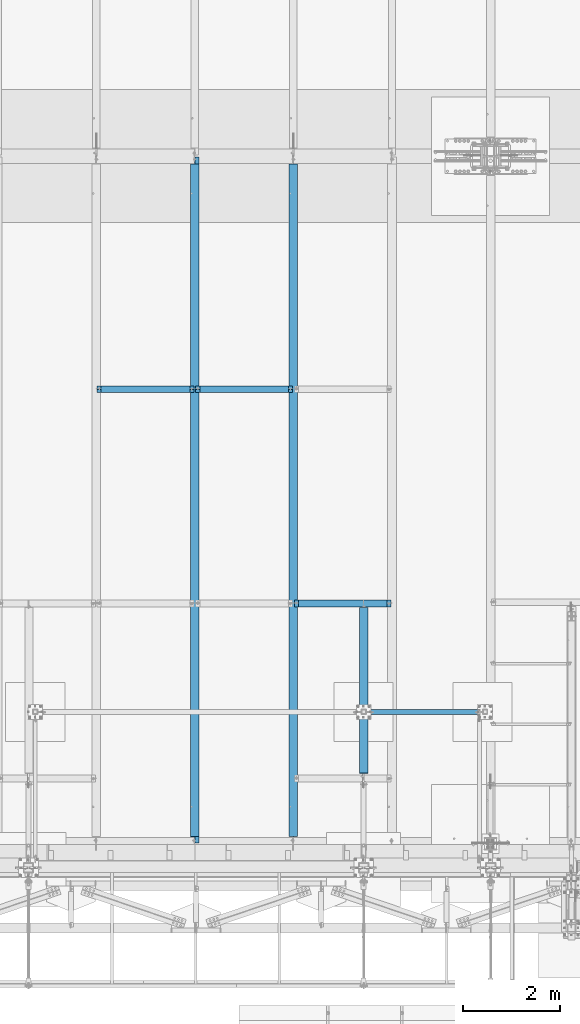
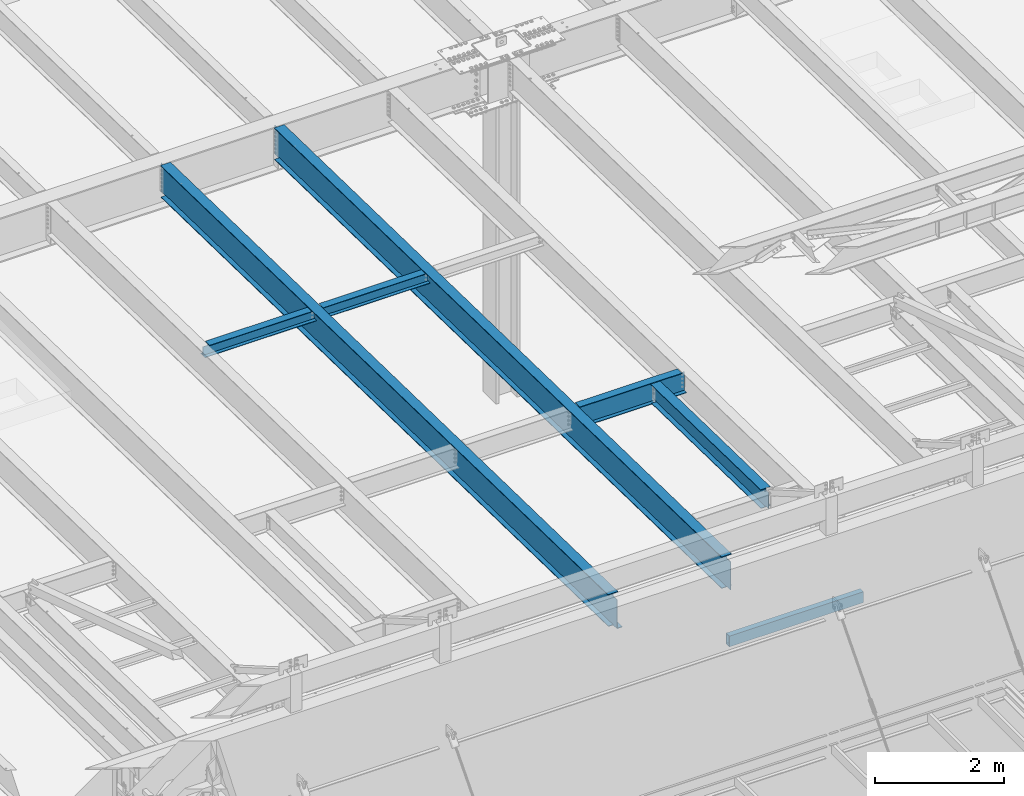
# One storey, part 1060 of 1763: 7 beams, 7 elements without a shape of their own.
"""IFC2X3 building model written with IfcOpenShell, lengths in millimetres."""

from ifc_helpers import new_model, si_unit, frame, origin_with_axes, place, context, subcontext, project, spatial, faceted_brep, material, type_object, element, aggregate, save


model = new_model("IFC2X3")

# Units and contexts
model_context = context("Model", 3, precision=1e-05, world=origin_with_axes())
body_context = subcontext(model_context, "Body", "Model", "MODEL_VIEW")
ifc_project = project(units=[si_unit("LENGTHUNIT", "METRE", prefix="MILLI"), si_unit("AREAUNIT", "SQUARE_METRE"), si_unit("VOLUMEUNIT", "CUBIC_METRE"), si_unit("MASSUNIT", "GRAM", prefix="KILO"), si_unit("TIMEUNIT", "SECOND"), si_unit("PLANEANGLEUNIT", "RADIAN"), si_unit("SOLIDANGLEUNIT", "STERADIAN"), si_unit("THERMODYNAMICTEMPERATUREUNIT", "DEGREE_CELSIUS"), si_unit("LUMINOUSINTENSITYUNIT", "LUMEN")], contexts=[model_context])

# Site, building, storey
site_placement = place(None, origin_with_axes())
site = spatial("IfcSite", under=ifc_project, at=site_placement, CompositionType="ELEMENT")
building_placement = place(site_placement, origin_with_axes())
building = spatial("IfcBuilding", under=site, at=building_placement, Name="Undefined", CompositionType="ELEMENT")
storey_placement = place(building_placement, origin_with_axes())
storey = spatial("IfcBuildingStorey", under=building, at=storey_placement, Name="Undefined", CompositionType="ELEMENT", Elevation=0.0)

# Assembly, beam
assembly_1_placement = place(storey_placement, origin_with_axes())
assembly_1 = element("IfcElementAssembly", 1, at=assembly_1_placement, inside=storey, Name="BEAM", AssemblyPlace="NOTDEFINED", PredefinedType="RIGID_FRAME")
ifc_material_1 = material(Name="STEEL/A992")
beam_type_1 = type_object("IfcBeamType", Name="W8X18", PredefinedType="NOTDEFINED")
beam_1_placement = place(assembly_1_placement, frame((-57530.4372736983, -4344.55643304548, 11905.5938232069), z_axis=(0.0, 0.0, 1.0), x_axis=(1.0, 0.0, 0.0)))
beam_1 = element("IfcBeam", 2, at=beam_1_placement, type_object=beam_type_1, material=ifc_material_1, Name="BEAM", ObjectType="W8X18", context=body_context, shape_type="Brep", body=[
    faceted_brep([(87.3125001907247, -3.17500000000018, 64.8275016680727), (87.3125001907247, 3.17500000000018, 64.8275016680727), (17.4624999999905, 3.17500000000018, 64.8275016680727), (17.4624999999905, -3.17500000000018, 64.8275016680727), (92.1725797087711, -3.17500000000018, 65.7942315906603), (92.1725797087711, 3.17500000000018, 65.7942315906603), (96.2927561769247, -3.17500000000018, 68.5472454911378), (96.2927561769247, 3.17500000000018, 68.5472454911378), (97.1527139098253, -3.17500000000018, 69.8342631898486), (97.1527139098253, 3.17500000000018, 69.8342631898486), (17.4624999999905, -3.17500000000018, -95.25), (17.4624999999905, -66.6750000000002, -95.25), (2014.53750000001, -66.6750000000002, -95.25), (2014.53750000001, -3.17500000000018, -95.25), (17.4624999999905, -66.6750000000002, -103.1875), (2014.53750000001, -66.6750000000002, -103.1875), (17.4624999999905, 66.6750000000002, -103.1875), (2014.53750000001, 66.6750000000002, -103.1875), (17.4624999999905, 66.6750000000002, -95.25), (2014.53750000001, 66.6750000000002, -95.25), (17.4624999999905, 3.17500000000018, -95.25), (2014.53750000001, 3.17500000000018, -95.25), (2014.53750000001, 3.17500000000018, 64.8275016741045), (2014.53750000001, -3.17500000000018, 64.8275016741045), (1944.68749980927, 3.17500000000018, 64.8275016741045), (1944.68749980927, -3.17500000000018, 64.8275016741045), (1939.82742029122, 3.17500000000018, 65.794231596692), (1939.82742029122, -3.17500000000018, 65.794231596692), (1935.70724382307, 3.17500000000018, 68.5472454971696), (1935.70724382307, -3.17500000000018, 68.5472454971696), (1934.84728609776, 3.17500000000018, 69.8342631845208), (1934.84728609776, -3.17500000000018, 69.8342631845208), (1934.11974687481, 3.17500000000018, 70.3203893515383), (1934.11974687481, -3.17500000000018, 70.3203893515383), (1931.36673297434, 3.17500000000018, 74.440565819692), (1931.36673297434, -3.17500000000018, 74.440565819692), (1930.40000305175, 3.17500000000018, 79.3006453377384), (1930.40000305175, -3.17500000000018, 79.3006453377384), (101.599996948244, 3.17500000000018, 95.25), (101.599996948244, 66.6750000000002, 95.25), (1930.40000305175, 66.6750000000002, 95.25), (1930.40000305175, 3.17500000000018, 95.25), (101.599996948244, -66.6750000000002, 103.1875), (101.599996948244, -66.6750000000002, 95.25), (1930.40000305175, -66.6750000000002, 95.25), (1930.40000305175, -66.6750000000002, 103.1875), (101.599996948244, 66.6750000000002, 103.1875), (1930.40000305175, 66.6750000000002, 103.1875), (1930.40000305175, -3.17500000000018, 95.25), (101.599996948244, -3.17500000000018, 95.25), (101.599996948244, 3.17500000000018, 79.3006453379949), (101.599996948244, -3.17500000000018, 79.3006453379949), (100.633267025656, 3.17500000000018, 74.4405658199485), (100.633267025656, -3.17500000000018, 74.4405658199485), (97.8802531251786, 3.17500000000018, 70.3203893517948), (97.8802531251786, -3.17500000000018, 70.3203893517948)], [[[0, 1, 2, 3]], [[4, 5, 1, 0]], [[6, 7, 5, 4]], [[8, 9, 7, 6]], [[10, 11, 12, 13]], [[11, 14, 15, 12]], [[14, 16, 17, 15]], [[16, 18, 19, 17]], [[18, 20, 21, 19]], [[13, 12, 15, 17, 19, 21, 22, 23]], [[23, 22, 24, 25]], [[25, 24, 26, 27]], [[27, 26, 28, 29]], [[29, 28, 30, 31]], [[32, 33, 31, 30]], [[33, 32, 34, 35]], [[35, 34, 36, 37]], [[38, 39, 40, 41]], [[42, 43, 44, 45]], [[46, 42, 45, 47]], [[39, 46, 47, 40]], [[45, 44, 48, 37, 36, 41, 40, 47]], [[43, 49, 48, 44]], [[42, 46, 39, 38, 50, 51, 49, 43]], [[51, 50, 52, 53]], [[53, 52, 54, 55]], [[4, 0, 3, 10, 13, 23, 25, 27, 29, 31, 33, 35, 37, 48, 49, 51, 53, 55, 8, 6]], [[20, 18, 16, 14, 11, 10, 3, 2]], [[54, 52, 50, 38, 41, 36, 34, 32, 30, 28, 26, 24, 22, 21, 20, 2, 1, 5, 7, 9]], [[55, 54, 9, 8]]]),
])
aggregate(assembly_1, [beam_1])

assembly_2_placement = place(storey_placement, origin_with_axes())
assembly_2 = element("IfcElementAssembly", 3, at=assembly_2_placement, inside=storey, Name="BEAM", AssemblyPlace="NOTDEFINED", PredefinedType="RIGID_FRAME")
beam_2_placement = place(assembly_2_placement, frame((-55498.4372736983, -4344.55643304548, 11905.5938232069), z_axis=(0.0, 0.0, 1.0), x_axis=(1.0, 0.0, 0.0)))
beam_2 = element("IfcBeam", 4, at=beam_2_placement, type_object=beam_type_1, material=ifc_material_1, Name="BEAM", ObjectType="W8X18", context=body_context, shape_type="Brep", body=[
    faceted_brep([(87.3125001907247, -3.17500000000018, 64.8275016680727), (87.3125001907247, 3.17500000000018, 64.8275016680727), (17.4624999999905, 3.17500000000018, 64.8275016680727), (17.4624999999905, -3.17500000000018, 64.8275016680727), (92.1725797087711, -3.17500000000018, 65.7942315906603), (92.1725797087711, 3.17500000000018, 65.7942315906603), (96.2927561769247, -3.17500000000018, 68.5472454911378), (96.2927561769247, 3.17500000000018, 68.5472454911378), (97.1527139098253, -3.17500000000018, 69.8342631898486), (97.1527139098253, 3.17500000000018, 69.8342631898486), (17.4624999999905, -3.17500000000018, -95.25), (17.4624999999905, -66.6750000000002, -95.25), (2014.53750000001, -66.6750000000002, -95.25), (2014.53750000001, -3.17500000000018, -95.25), (17.4624999999905, -66.6750000000002, -103.1875), (2014.53750000001, -66.6750000000002, -103.1875), (17.4624999999905, 66.6750000000002, -103.1875), (2014.53750000001, 66.6750000000002, -103.1875), (17.4624999999905, 66.6750000000002, -95.25), (2014.53750000001, 66.6750000000002, -95.25), (17.4624999999905, 3.17500000000018, -95.25), (2014.53750000001, 3.17500000000018, -95.25), (2014.53750000001, 3.17500000000018, 64.8275016741045), (2014.53750000001, -3.17500000000018, 64.8275016741045), (1944.68749980927, 3.17500000000018, 64.8275016741045), (1944.68749980927, -3.17500000000018, 64.8275016741045), (1939.82742029122, 3.17500000000018, 65.794231596692), (1939.82742029122, -3.17500000000018, 65.794231596692), (1935.70724382307, 3.17500000000018, 68.5472454971696), (1935.70724382307, -3.17500000000018, 68.5472454971696), (1934.84728609776, 3.17500000000018, 69.8342631845208), (1934.84728609776, -3.17500000000018, 69.8342631845208), (1934.11974687481, 3.17500000000018, 70.3203893515383), (1934.11974687481, -3.17500000000018, 70.3203893515383), (1931.36673297434, 3.17500000000018, 74.440565819692), (1931.36673297434, -3.17500000000018, 74.440565819692), (1930.40000305175, 3.17500000000018, 79.3006453377384), (1930.40000305175, -3.17500000000018, 79.3006453377384), (101.599996948244, 3.17500000000018, 95.25), (101.599996948244, 66.6750000000002, 95.25), (1930.40000305175, 66.6750000000002, 95.25), (1930.40000305175, 3.17500000000018, 95.25), (101.599996948244, -66.6750000000002, 103.1875), (101.599996948244, -66.6750000000002, 95.25), (1930.40000305175, -66.6750000000002, 95.25), (1930.40000305175, -66.6750000000002, 103.1875), (101.599996948244, 66.6750000000002, 103.1875), (1930.40000305175, 66.6750000000002, 103.1875), (1930.40000305175, -3.17500000000018, 95.25), (101.599996948244, -3.17500000000018, 95.25), (101.599996948244, 3.17500000000018, 79.3006453379949), (101.599996948244, -3.17500000000018, 79.3006453379949), (100.633267025656, 3.17500000000018, 74.4405658199485), (100.633267025656, -3.17500000000018, 74.4405658199485), (97.8802531251786, 3.17500000000018, 70.3203893517948), (97.8802531251786, -3.17500000000018, 70.3203893517948)], [[[0, 1, 2, 3]], [[4, 5, 1, 0]], [[6, 7, 5, 4]], [[8, 9, 7, 6]], [[10, 11, 12, 13]], [[11, 14, 15, 12]], [[14, 16, 17, 15]], [[16, 18, 19, 17]], [[18, 20, 21, 19]], [[13, 12, 15, 17, 19, 21, 22, 23]], [[23, 22, 24, 25]], [[25, 24, 26, 27]], [[27, 26, 28, 29]], [[29, 28, 30, 31]], [[32, 33, 31, 30]], [[33, 32, 34, 35]], [[35, 34, 36, 37]], [[38, 39, 40, 41]], [[42, 43, 44, 45]], [[46, 42, 45, 47]], [[39, 46, 47, 40]], [[45, 44, 48, 37, 36, 41, 40, 47]], [[43, 49, 48, 44]], [[42, 46, 39, 38, 50, 51, 49, 43]], [[51, 50, 52, 53]], [[53, 52, 54, 55]], [[4, 0, 3, 10, 13, 23, 25, 27, 29, 31, 33, 35, 37, 48, 49, 51, 53, 55, 8, 6]], [[20, 18, 16, 14, 11, 10, 3, 2]], [[54, 52, 50, 38, 41, 36, 34, 32, 30, 28, 26, 24, 22, 21, 20, 2, 1, 5, 7, 9]], [[55, 54, 9, 8]]]),
])
aggregate(assembly_2, [beam_2])

assembly_3_placement = place(storey_placement, origin_with_axes())
assembly_3 = element("IfcElementAssembly", 5, at=assembly_3_placement, inside=storey, Name="BEAM", AssemblyPlace="NOTDEFINED", PredefinedType="RIGID_FRAME")
beam_type_2 = type_object("IfcBeamType", Name="W14X30", PredefinedType="NOTDEFINED")
beam_3_placement = place(assembly_3_placement, frame((-52018.6372736983, -12375.7975361719, 12000.4308275578), z_axis=(0.0, 0.0209013539966291, 0.999781542838788), x_axis=(0.0, 0.999781542776098, -0.0209013569953182)))
beam_3 = element("IfcBeam", 6, at=beam_3_placement, type_object=beam_type_2, material=ifc_material_1, Name="BEAM", ObjectType="W14X30", context=body_context, shape_type="Brep", body=[
    faceted_brep([(3499.73692840905, -3.17500000000291, -166.687500001286), (3499.73692840905, -85.7249999999985, -166.687500001286), (3499.73692840905, -85.7249999999985, -176.212500001295), (3499.73692840905, 85.7249999999985, -176.212500001295), (3499.73692840905, 85.7249999999985, -166.687500001286), (3499.73692840905, 3.17500000000291, -166.687500001286), (3499.73692840906, 3.17500000000291, -163.51249981689), (3499.73692840906, -3.17500000000291, -163.51249981689), (3500.70365833165, 3.17500000000291, -158.652420298831), (3500.70365833165, -3.17500000000291, -158.652420298831), (3503.45667223214, 3.17500000000291, -154.532243830672), (3503.45667223214, -3.17500000000291, -154.532243830672), (3507.5768487003, 3.17500000000291, -151.779229930187), (3507.5768487003, -3.17500000000291, -151.779229930187), (3512.43692821836, 3.17500000000291, -150.812500007598), (3512.43692821836, -3.17500000000291, -150.812500007598), (3600.80591795297, -3.17500000000291, -150.812500007625), (3600.80591795297, 3.17500000000291, -150.812500007625), (111.128437087651, 3.17500000000291, 166.687500000098), (111.128437087651, 85.7249999999985, 166.687500000098), (3525.13692840938, 85.7249999999985, 166.687499998974), (3525.13692840938, 3.17500000000291, 166.687499998974), (111.128437087542, -3.17500000000291, -163.512499809849), (111.128437087542, 3.17500000000291, -163.512499809849), (111.12843708754, 3.17500000000291, -166.687500000171), (111.12843708754, 85.7249999999985, -166.687500000171), (111.128437087536, 85.7249999999985, -176.212500000178), (111.128437087536, -85.7249999999985, -176.212500000178), (111.12843708754, -85.7249999999985, -166.687500000171), (111.12843708754, -3.17500000000291, -166.687500000171), (110.161707164953, -3.17500000000291, -158.65242029179), (110.161707164953, 3.17500000000291, -158.65242029179), (107.408693264468, -3.17500000000291, -154.532243823627), (107.408693264468, 3.17500000000291, -154.532243823627), (103.288516796305, -3.17500000000291, -151.779229923141), (103.288516796305, 3.17500000000291, -151.779229923141), (98.4284372782495, -3.17500000000291, -150.812500000549), (98.4284372782495, 3.17500000000291, -150.812500000549), (22.7151965710145, -3.17500000000291, -150.812500000524), (22.7151965710145, 3.17500000000291, -150.812500000524), (16.40944753248, -3.17500000000291, 150.812500000327), (16.40944753248, 3.17500000000291, 150.812500000327), (98.4284372783495, -3.17500000000291, 150.8125000003), (98.4284372783495, 3.17500000000291, 150.8125000003), (103.288516796405, -3.17500000000291, 151.779229922889), (103.288516796405, 3.17500000000291, 151.779229922889), (107.408693264571, -3.17500000000291, 154.532243823371), (107.408693264571, 3.17500000000291, 154.532243823371), (110.161707165056, -3.17500000000291, 158.652420291533), (110.161707165056, 3.17500000000291, 158.652420291533), (111.128437087647, -3.17500000000291, 163.512499809589), (111.128437087647, 3.17500000000291, 163.512499809589), (111.128437087651, -85.7249999999985, 176.212500000105), (111.128437087651, 85.7249999999985, 176.212500000105), (111.128437087651, -3.17500000000291, 166.687500000098), (111.128437087651, -85.7249999999985, 166.687500000098), (3525.13692840938, -3.17500000000291, 166.687499998974), (3525.13692840938, -85.7249999999985, 166.687499998974), (3525.13692840938, -85.7249999999985, 176.212499998981), (3525.13692840938, 85.7249999999985, 176.212499998981), (3525.13692840938, -3.17500000000291, 163.512499802697), (3525.13692840938, 3.17500000000291, 163.512499802697), (3526.10365833196, -3.17500000000291, 158.652420284639), (3526.10365833196, 3.17500000000291, 158.652420284639), (3528.85667223244, -3.17500000000291, 154.532243816475), (3528.85667223244, 3.17500000000291, 154.532243816475), (3532.97684870061, -3.17500000000291, 151.77922991599), (3532.97684870061, 3.17500000000291, 151.77922991599), (3537.83692821866, -3.17500000000291, 150.812499993397), (3537.83692821866, 3.17500000000291, 150.812499993397), (3594.50016891443, -3.17500000000291, 150.812499993381), (3594.50016891443, 3.17500000000291, 150.812499993381)], [[[0, 1, 2, 3, 4, 5, 6, 7]], [[7, 6, 8, 9]], [[9, 8, 10, 11]], [[11, 10, 12, 13]], [[13, 12, 14, 15]], [[16, 15, 14, 17]], [[18, 19, 20, 21]], [[22, 23, 24, 25, 26, 27, 28, 29]], [[30, 31, 23, 22]], [[32, 33, 31, 30]], [[34, 35, 33, 32]], [[36, 37, 35, 34]], [[38, 39, 37, 36]], [[40, 41, 39, 38]], [[42, 43, 41, 40]], [[44, 45, 43, 42]], [[46, 47, 45, 44]], [[48, 49, 47, 46]], [[50, 51, 49, 48]], [[52, 53, 19, 18, 51, 50, 54, 55]], [[55, 54, 56, 57]], [[52, 55, 57, 58]], [[53, 52, 58, 59]], [[19, 53, 59, 20]], [[58, 57, 56, 60, 61, 21, 20, 59]], [[62, 63, 61, 60]], [[64, 65, 63, 62]], [[66, 67, 65, 64]], [[68, 69, 67, 66]], [[70, 71, 69, 68]], [[71, 70, 16, 17]], [[12, 10, 8, 6, 5, 24, 23, 31, 33, 35, 37, 39, 41, 43, 45, 47, 49, 51, 18, 21, 61, 63, 65, 67, 69, 71, 17, 14]], [[25, 24, 5, 4]], [[26, 25, 4, 3]], [[27, 26, 3, 2]], [[28, 27, 2, 1]], [[29, 28, 1, 0]], [[70, 68, 66, 64, 62, 60, 56, 54, 50, 48, 46, 44, 42, 40, 38, 36, 34, 32, 30, 22, 29, 0, 7, 9, 11, 13, 15, 16]]]),
])
aggregate(assembly_3, [beam_3])

assembly_4_placement = place(storey_placement, origin_with_axes())
assembly_4 = element("IfcElementAssembly", 7, at=assembly_4_placement, inside=storey, Name="BEAM", AssemblyPlace="NOTDEFINED", PredefinedType="RIGID_FRAME")
beam_type_3 = type_object("IfcBeamType", Name="W16X26", PredefinedType="NOTDEFINED")
beam_4_placement = place(assembly_4_placement, frame((-53466.4372736983, -8763.05542596541, 11901.1291231283), z_axis=(0.0, 0.0, 1.0), x_axis=(1.0, 0.0, 0.0)))
beam_4 = element("IfcBeam", 8, at=beam_4_placement, type_object=beam_type_3, material=ifc_material_1, Name="BEAM", ObjectType="W16X26", context=body_context, shape_type="Brep", body=[
    faceted_brep([(87.312500190732, -3.17499999999927, 161.665001675578), (87.312500190732, 3.17499999999927, 161.665001675578), (17.4624999999942, 3.17499999999927, 161.665001675578), (17.4624999999942, -3.17499999999927, 161.665001675578), (92.1725797087784, -3.17499999999927, 162.631731598165), (92.1725797087784, 3.17499999999927, 162.631731598165), (96.292756176932, -3.17499999999927, 165.384745498643), (96.292756176932, 3.17499999999927, 165.384745498643), (97.1527139056197, -3.17499999999927, 166.671763191049), (97.1527139056197, 3.17499999999927, 166.671763191049), (17.4625000000087, -3.17499999999927, -190.5), (17.4625000000087, -69.8500000000004, -190.5), (2014.53750000001, -69.8500000000004, -190.5), (2014.53750000001, -3.17499999999927, -190.5), (17.4625000000087, -69.8500000000004, -200.025), (2014.53750000001, -69.8500000000004, -200.025), (17.4625000000087, 69.8500000000004, -200.025), (2014.53750000001, 69.8500000000004, -200.025), (17.4625000000087, 69.8500000000004, -190.5), (2014.53750000001, 69.8500000000004, -190.5), (17.4625000000087, 3.17499999999927, -190.5), (2014.53750000001, 3.17499999999927, -190.5), (2014.53750000001, 3.17499999999927, 161.665001678701), (2014.53750000001, -3.17499999999927, 161.665001678701), (1944.68749980927, 3.17499999999927, 161.665001678701), (1944.68749980927, -3.17499999999927, 161.665001678701), (1939.82742029122, 3.17499999999927, 162.631731601288), (1939.82742029122, -3.17499999999927, 162.631731601288), (1935.70724382307, 3.17499999999927, 165.384745501766), (1935.70724382307, -3.17499999999927, 165.384745501766), (1934.84728609816, 3.17499999999927, 166.671763188517), (1934.84728609816, -3.17499999999927, 166.671763188517), (1934.11974687481, 3.17499999999927, 167.157889355802), (1934.11974687481, -3.17499999999927, 167.157889355802), (1931.36673297434, 3.17499999999927, 171.278065823955), (1931.36673297434, -3.17499999999927, 171.278065823955), (1930.40000305175, 3.17499999999927, 176.138145342002), (1930.40000305175, -3.17499999999927, 176.138145342002), (101.599996948236, 3.17499999999927, 190.5), (101.599996948236, 69.8500000000004, 190.5), (1930.40000305175, 69.8500000000004, 190.5), (1930.40000305175, 3.17499999999927, 190.5), (101.599996948236, -69.8500000000004, 200.025), (101.599996948236, -69.8500000000004, 190.5), (1930.40000305175, -69.8500000000004, 190.5), (1930.40000305175, -69.8500000000004, 200.025), (101.599996948236, 69.8500000000004, 200.025), (1930.40000305175, 69.8500000000004, 200.025), (1930.40000305175, -3.17499999999927, 190.5), (101.599996948236, -3.17499999999927, 190.5), (101.599996948236, 3.17499999999927, 176.138145342), (101.599996948236, -3.17499999999927, 176.138145342), (100.633267025645, 3.17499999999927, 171.278065823954), (100.633267025645, -3.17499999999927, 171.278065823954), (97.8802531251713, 3.17499999999927, 167.1578893558), (97.8802531251713, -3.17499999999927, 167.1578893558)], [[[0, 1, 2, 3]], [[4, 5, 1, 0]], [[6, 7, 5, 4]], [[8, 9, 7, 6]], [[10, 11, 12, 13]], [[11, 14, 15, 12]], [[14, 16, 17, 15]], [[16, 18, 19, 17]], [[18, 20, 21, 19]], [[13, 12, 15, 17, 19, 21, 22, 23]], [[23, 22, 24, 25]], [[25, 24, 26, 27]], [[27, 26, 28, 29]], [[29, 28, 30, 31]], [[32, 33, 31, 30]], [[33, 32, 34, 35]], [[35, 34, 36, 37]], [[38, 39, 40, 41]], [[42, 43, 44, 45]], [[46, 42, 45, 47]], [[39, 46, 47, 40]], [[45, 44, 48, 37, 36, 41, 40, 47]], [[43, 49, 48, 44]], [[42, 46, 39, 38, 50, 51, 49, 43]], [[51, 50, 52, 53]], [[53, 52, 54, 55]], [[4, 0, 3, 10, 13, 23, 25, 27, 29, 31, 33, 35, 37, 48, 49, 51, 53, 55, 8, 6]], [[20, 18, 16, 14, 11, 10, 3, 2]], [[54, 52, 50, 38, 41, 36, 34, 32, 30, 28, 26, 24, 22, 21, 20, 2, 1, 5, 7, 9]], [[55, 54, 9, 8]]]),
])
aggregate(assembly_4, [beam_4])

assembly_5_placement = place(storey_placement, origin_with_axes())
assembly_5 = element("IfcElementAssembly", 9, at=assembly_5_placement, inside=storey, Name="BEAM", AssemblyPlace="NOTDEFINED", PredefinedType="RIGID_FRAME")
ifc_material_2 = material()
beam_type_4 = type_object("IfcBeamType", Name="HSS8X4X3/8", PredefinedType="NOTDEFINED")
beam_5_placement = place(assembly_5_placement, frame((-51967.8372736478, -10998.1999679201, 8521.70000000128), z_axis=(0.0, 0.0, 1.0), x_axis=(1.0, 0.0, 0.0)))
beam_5 = element("IfcBeam", 10, at=beam_5_placement, type_object=beam_type_4, material=ifc_material_2, Name="BEAM", ObjectType="HSS8X4X3/8", context=body_context, shape_type="Brep", body=[
    faceted_brep([(1.58750000000146, 41.2749999999996, -92.0750000000007), (1.58750000000146, -41.2749999999996, -92.0750000000007), (2398.69530781683, -41.2749999999996, -92.0750000000007), (2398.69530781683, 41.2749999999996, -92.0750000000007), (1.58750000000146, -41.2749999999996, 92.0750000000007), (2398.69530781683, -41.2749999999996, 92.0750000000007), (1.58750000000146, 41.2749999999996, 92.0750000000007), (2398.69530781683, 41.2749999999996, 92.0750000000007), (1.58750000000146, 50.7999999999993, -101.6), (1.58750000000146, 50.7999999999993, 101.6), (2398.69530781683, 50.7999999999993, 101.6), (2398.69530781683, 50.7999999999993, -101.6), (1.58750000000146, -50.7999999999993, 101.6), (2398.69530781683, -50.7999999999993, 101.6), (1.58750000000146, -50.7999999999993, -101.6), (2398.69530781683, -50.7999999999993, -101.6)], [[[0, 1, 2, 3]], [[1, 4, 5, 2]], [[4, 6, 7, 5]], [[6, 0, 3, 7]], [[8, 9, 10, 11]], [[9, 12, 13, 10]], [[12, 14, 15, 13]], [[14, 8, 11, 15]], [[13, 15, 11, 10], [5, 7, 3, 2]], [[14, 12, 9, 8], [6, 4, 1, 0]]]),
])
aggregate(assembly_5, [beam_5])

assembly_6_placement = place(storey_placement, origin_with_axes())
assembly_6 = element("IfcElementAssembly", 11, at=assembly_6_placement, inside=storey, Name="BEAM", AssemblyPlace="NOTDEFINED", PredefinedType="RIGID_FRAME")
beam_type_5 = type_object("IfcBeamType", Name="W24X55", PredefinedType="NOTDEFINED")
beam_6_placement = place(assembly_6_placement, frame((-53466.4372736983, -13722.2711313756, 11904.7280453544), z_axis=(0.0, 0.0209013539966291, 0.999781542838788), x_axis=(0.0, 0.999781542776098, -0.0209013569953182)))
beam_6 = element("IfcBeam", 12, at=beam_6_placement, type_object=beam_type_5, material=ifc_material_1, Name="BEAM", ObjectType="W24X55", context=body_context, shape_type="Brep", body=[
    faceted_brep([(14016.593893803, 4.76249999999709, -287.337500004851), (14016.593893803, 4.76238284193096, -300.037500004859), (14016.5938910267, 88.9000000000015, -300.037500004861), (14016.5938910267, 88.9000000000015, -287.337500004851), (14118.1827906951, 4.76299991607812, -300.037500004893), (14117.9172854725, 4.76249999999709, -287.337500004882), (165.102558712022, -4.76249999999709, -287.337500000289), (165.102558712022, -88.9000000000015, -287.337500000289), (14016.5938907292, -88.9000000000015, -287.337500004849), (14016.5938879523, -4.76249999999709, -287.337500004849), (153.198208143893, 4.76249999999709, 287.33750000018), (153.198208143893, 88.9000000000015, 287.33750000018), (14016.5938908944, 88.9000000000015, 287.33749999561), (14016.5938908944, 4.76249999999709, 287.33749999561), (153.198208143898, -88.9000000000015, 300.037500000191), (153.198208143898, 88.9000000000015, 300.037500000191), (153.198208143884, 4.76249999999709, 261.937499809663), (153.198208143884, -4.76249999999709, 261.937499809663), (153.198208143893, -4.76249999999709, 287.33750000018), (153.198208143893, -88.9000000000015, 287.33750000018), (152.50805080805, -4.76249999999709, 258.467844579442), (152.231478221292, 4.76249999999709, 257.077420291605), (152.231478221292, -4.76249999999709, 257.077420291605), (149.478464320808, 4.76249999999709, 252.957243823441), (149.478464320808, -4.76249999999709, 252.957243823441), (145.358287852643, 4.76249999999709, 250.204229922958), (145.358287852643, -4.76249999999709, 250.204229922958), (140.498208334584, 4.76249999999709, 249.237500000372), (140.498208334584, -4.76249999999709, 249.237500000372), (20.9102290337687, 4.76249999999709, 249.23750000041), (20.9102290337687, -4.76249999999709, 249.23750000041), (31.9459431613013, 4.76249999999709, -278.637500001068), (31.9459431613013, -4.76249999999709, -278.637500001068), (153.198208334481, 4.76249999999709, -278.637500001108), (153.198208334481, -4.76249999999709, -278.637500001108), (158.058287852537, 4.76249999999709, -279.6042299237), (158.058287852537, -4.76249999999709, -279.6042299237), (162.178464320699, 4.76249999999709, -282.357243824186), (162.178464320699, -4.76249999999709, -282.357243824186), (163.867339899425, -4.76249999999709, -284.884824747733), (164.93147822118, 4.76249999999709, -286.477420292351), (164.93147822118, -4.76249999999709, -286.477420292351), (165.102558712022, 4.76249999999709, -287.337500000289), (165.102558712022, 88.9000000000015, -287.337500000289), (165.89820814377, 88.9000000000015, -291.337499810408), (165.89820814377, -88.9000000000015, -291.337499810408), (165.898208143768, 88.9000000000015, -300.037500000297), (165.898208143768, -88.9000000000015, -300.037500000297), (14016.5938907292, -88.9000000000015, -300.037500004861), (14016.5938879524, -4.76262320829846, -300.037500004861), (14118.182790722, -4.76200008393062, -300.037500004893), (14117.9172854725, -4.76249999999709, -287.337500004882), (14168.9938907729, -4.76200008393062, -300.03750000491), (14168.7283855234, -4.76249999999709, -287.3375000049), (14168.993890746, 4.76299991607812, -300.03750000491), (14168.7283855234, 4.76249999999709, -287.3375000049), (14168.3301609801, -4.76249999999709, -268.289092414178), (14168.3301647496, 4.76249999999709, -268.289272721053), (14157.6435424792, 4.76249999999709, 242.887499877306), (14157.6435424792, -4.76249999999709, 242.887499877306), (14024.4338111857, -4.76249999999709, 243.854229799896), (14020.3136347175, -4.76249999999709, 246.607243700379), (14017.560620817, -4.76249999999709, 250.727420168543), (14016.5938908944, -4.76249999999709, 255.5874996866), (14016.5938908944, -4.76249999999709, 287.33749999561), (14029.2938907037, -4.76249999999709, 242.887499877303), (14016.5938908944, -88.9000000000015, 287.33749999561), (14016.5938908944, -88.9000000000015, 300.037499995622), (14016.5938908944, 88.9000000000015, 300.037499995622), (14016.5938908944, 4.76249999999709, 255.5874996866), (14017.560620817, 4.76249999999709, 250.727420168543), (14020.3136347175, 4.76249999999709, 246.607243700379), (14024.4338111857, 4.76249999999709, 243.854229799896), (14029.2938907037, 4.76249999999709, 242.887499877303)], [[[0, 1, 2, 3]], [[4, 1, 0, 5]], [[6, 7, 8, 9]], [[10, 11, 12, 13]], [[14, 15, 11, 10, 16, 17, 18, 19]], [[20, 17, 16, 21, 22]], [[22, 21, 23, 24]], [[24, 23, 25, 26]], [[26, 25, 27, 28]], [[28, 27, 29, 30]], [[30, 29, 31, 32]], [[32, 31, 33, 34]], [[34, 33, 35, 36]], [[36, 35, 37, 38]], [[39, 38, 37, 40, 41]], [[7, 6, 41, 40, 42, 43, 44, 45]], [[45, 44, 46, 47]], [[7, 45, 47, 48, 8]], [[8, 48, 49, 9]], [[50, 51, 9, 49]], [[52, 53, 51, 50]], [[54, 4, 5, 55]], [[56, 53, 52, 54, 55, 57, 58, 59]], [[60, 61, 62, 63, 64, 18, 17, 20, 22, 24, 26, 28, 30, 32, 34, 36, 38, 39, 41, 6, 9, 51, 53, 56, 59, 65]], [[19, 18, 64, 66]], [[14, 19, 66, 67]], [[15, 14, 67, 68]], [[11, 15, 68, 12]], [[67, 66, 64, 63, 69, 13, 12, 68]], [[62, 70, 69, 63]], [[61, 71, 70, 62]], [[60, 72, 71, 61]], [[65, 73, 72, 60]], [[59, 58, 73, 65]], [[57, 55, 5, 0, 42, 40, 37, 35, 33, 31, 29, 27, 25, 23, 21, 16, 10, 13, 69, 70, 71, 72, 73, 58]], [[43, 42, 0, 3]], [[46, 44, 43, 3, 2]], [[54, 52, 50, 49, 48, 47, 46, 2, 1, 4]]]),
])
aggregate(assembly_6, [beam_6])

assembly_7_placement = place(storey_placement, origin_with_axes())
assembly_7 = element("IfcElementAssembly", 13, at=assembly_7_placement, inside=storey, Name="BEAM", AssemblyPlace="NOTDEFINED", PredefinedType="RIGID_FRAME")
beam_7_placement = place(assembly_7_placement, frame((-55498.4372736983, -13722.2711313756, 11904.7280453544), z_axis=(0.0, 0.0209013539966291, 0.999781542838788), x_axis=(0.0, 0.999781542776098, -0.0209013569953182)))
beam_7 = element("IfcBeam", 14, at=beam_7_placement, type_object=beam_type_5, material=ifc_material_1, Name="BEAM", ObjectType="W24X55", context=body_context, shape_type="Brep", body=[
    faceted_brep([(14016.6713189086, 5.06262333965424, -287.337500004851), (14016.6713189087, 5.06237371335737, -300.037500004863), (14016.6713136267, 88.9000000000015, -300.037500004863), (14016.6713136267, 88.9000000000015, -287.337500004851), (14168.9938907462, 5.06238331007626, -300.03750000491), (14168.7283855236, 5.06263291966025, -287.3375000049), (153.120769029569, 4.76249999999709, 287.33750000018), (153.120769029569, 88.9000000000015, 287.33750000018), (14016.6713298856, 88.9000000000015, 287.33749999561), (14016.6713298856, 4.76249999999709, 287.33749999561), (153.120769029574, -88.9000000000015, 300.03750000019), (153.120769029574, 88.9000000000015, 300.03750000019), (153.12076902956, 4.76249999999709, 261.67750148814), (153.12076902956, -4.76249999999709, 261.67750148814), (153.120769029569, -4.76249999999709, 287.33750000018), (153.120769029569, -88.9000000000015, 287.33750000018), (152.15403910697, 4.76249999999709, 256.817421970085), (152.15403910697, -4.76249999999709, 256.817421970085), (149.401025206482, 4.76249999999709, 252.697245501922), (149.401025206482, -4.76249999999709, 252.697245501922), (145.280848738317, 4.76249999999709, 249.944231601437), (145.280848738317, -4.76249999999709, 249.944231601437), (140.42076922026, 4.76249999999709, 248.977501678848), (140.42076922026, -4.76249999999709, 248.977501678848), (20.9156645386702, 4.76249999999709, 248.977501678888), (20.9156645386702, -4.76249999999709, 248.977501678888), (32.1278246917773, -4.76249999999709, -287.337500000243), (32.1278246917773, -88.9000000000015, -287.337500000243), (14168.7283855236, -88.9000000000015, -287.3375000049), (14168.7283855234, -4.76249999999709, -287.3375000049), (14024.5112501769, -4.76249999999709, 243.594227663818), (14020.3910737087, -4.76249999999709, 246.347241564303), (14017.6380598082, -4.76249999999709, 250.467418032464), (14016.6713298856, -4.76249999999709, 255.327497550523), (14016.6713298856, -4.76249999999709, 287.33749999561), (14157.648978064, -4.76249999999709, 242.627497741229), (14029.3713296949, -4.76249999999709, 242.627497741227), (14016.6713298856, -88.9000000000015, 287.33749999561), (14016.6713298856, -88.9000000000015, 300.03749999562), (14016.6713298856, 88.9000000000015, 300.03749999562), (14016.6713298856, 4.76249999999709, 255.327497550523), (14017.6380598082, 4.76249999999709, 250.467418032464), (14020.3910737087, 4.76249999999709, 246.347241564303), (14024.5112501769, 4.76249999999709, 243.594227663818), (14029.3713296949, 4.76249999999709, 242.627497741227), (14157.648978064, 4.76249999999709, 242.627497741229), (14168.7283855234, 4.76249999999709, -287.3375000049), (32.1278246917773, 4.76249999999709, -287.337500000243), (153.120588301108, 88.9000000000015, -287.337500000282), (153.120588301104, 88.9000000000015, -300.037500000293), (153.120599954549, 5.06262326912838, -300.037500000293), (153.120599954584, 5.06237364569824, -287.337500000282), (32.3933299144519, 5.06260648809985, -300.037500000253), (32.1278246917773, 5.06235682772967, -287.337500000243), (32.3933299144519, -88.9000000000015, -300.037500000253), (14168.9938907462, -88.9000000000015, -300.03750000491)], [[[0, 1, 2, 3]], [[4, 1, 0, 5]], [[6, 7, 8, 9]], [[10, 11, 7, 6, 12, 13, 14, 15]], [[13, 12, 16, 17]], [[17, 16, 18, 19]], [[19, 18, 20, 21]], [[21, 20, 22, 23]], [[23, 22, 24, 25]], [[26, 27, 28, 29]], [[30, 31, 32, 33, 34, 14, 13, 17, 19, 21, 23, 25, 26, 29, 35, 36]], [[15, 14, 34, 37]], [[10, 15, 37, 38]], [[11, 10, 38, 39]], [[7, 11, 39, 8]], [[38, 37, 34, 33, 40, 9, 8, 39]], [[32, 41, 40, 33]], [[31, 42, 41, 32]], [[30, 43, 42, 31]], [[36, 44, 43, 30]], [[35, 45, 44, 36]], [[46, 47, 24, 22, 20, 18, 16, 12, 6, 9, 40, 41, 42, 43, 44, 45]], [[48, 49, 50, 51]], [[51, 50, 52, 53]], [[54, 27, 26, 25, 24, 47, 53, 52]], [[27, 54, 55, 28]], [[46, 45, 35, 29, 28, 55, 4, 5]], [[3, 48, 51, 53, 47, 46, 5, 0]], [[49, 48, 3, 2]], [[55, 54, 52, 50, 49, 2, 1, 4]]]),
])
aggregate(assembly_7, [beam_7])

save(model, "model.ifc")
